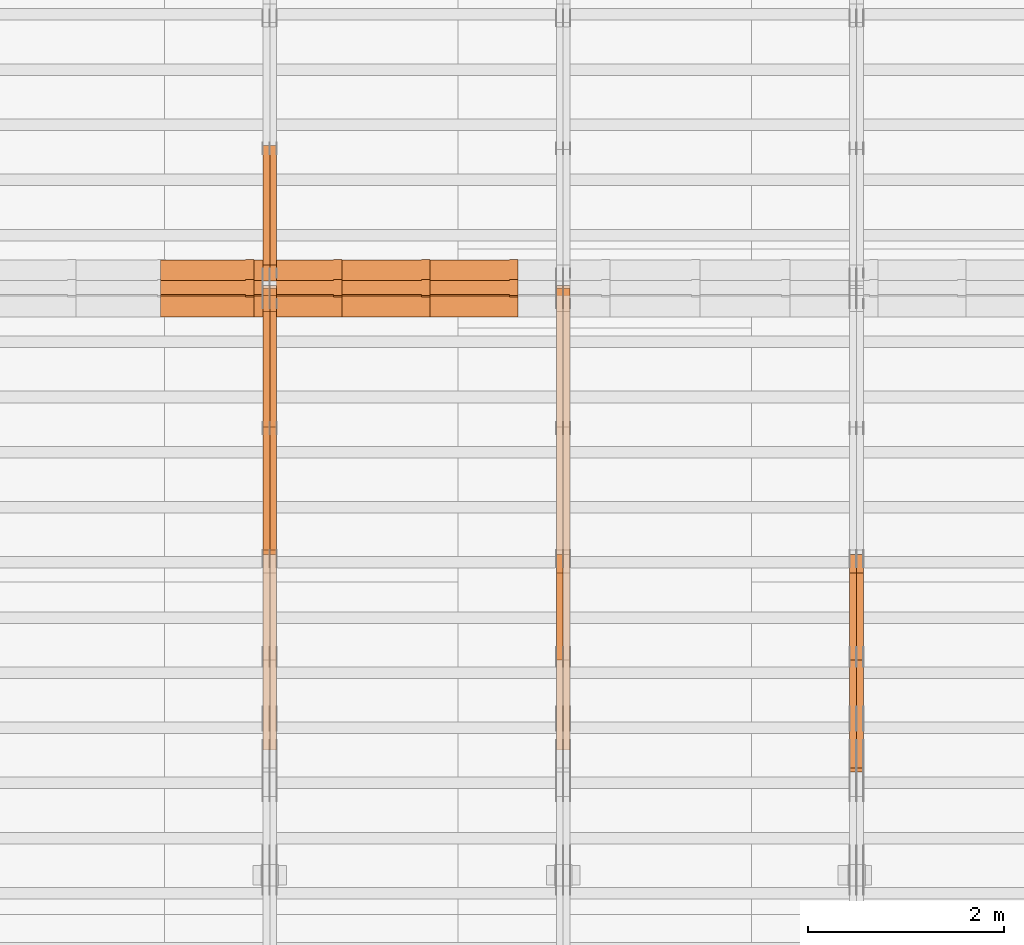
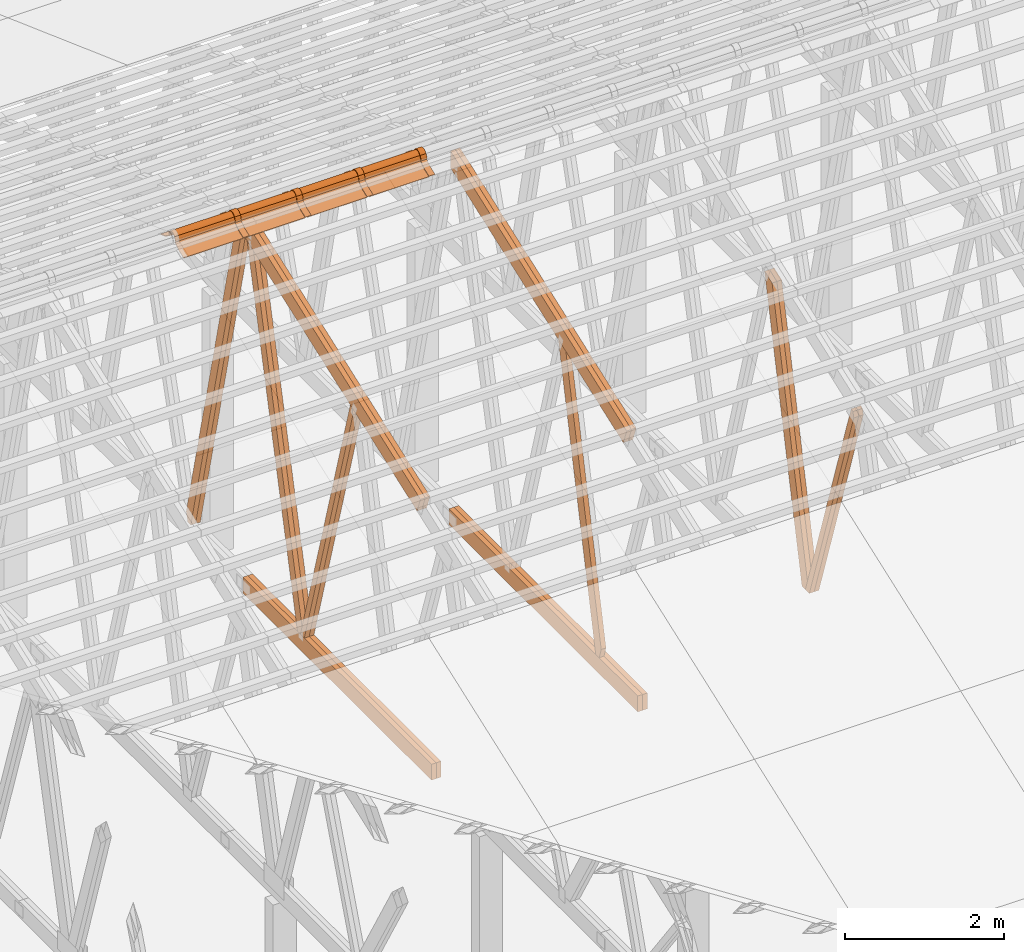
# One storey, part 29 of 189: 27 proxies.
"""IFC2X3 building model written with IfcOpenShell, lengths in millimetres."""

from ifc_helpers import new_model, entity, si_unit, converted_unit, derived_unit, direction, frame, frame_2d, origin, origin_2d_with_axis, place, context, subcontext, project, spatial, polyline, circle_curve, parameter, trimmed, segment, composite_curve, rectangle, outline, extrude, source, transform, mapped, material, type_object, type_shapes, element, save


model = new_model("IFC2X3")

# Units and contexts
model_context = context("Model", 3, precision=0.01, world=origin(), true_north=direction((6.12303176911189e-17, 1.0)))
body_context = subcontext(model_context, "Body", "Model", "MODEL_VIEW")
ifc_project = project(units=[si_unit("LENGTHUNIT", "METRE", prefix="MILLI"), si_unit("AREAUNIT", "SQUARE_METRE"), si_unit("VOLUMEUNIT", "CUBIC_METRE"), converted_unit("PLANEANGLEUNIT", "DEGREE", entity("IfcRatioMeasure", 0.0174532925199433), si_unit("PLANEANGLEUNIT", "RADIAN"), dimensions=[0, 0, 0, 0, 0, 0, 0]), si_unit("MASSUNIT", "GRAM", prefix="KILO"), derived_unit("MASSDENSITYUNIT", [(si_unit("MASSUNIT", "GRAM", prefix="KILO"), 1), (si_unit("LENGTHUNIT", "METRE"), -3)]), si_unit("TIMEUNIT", "SECOND"), si_unit("FREQUENCYUNIT", "HERTZ"), si_unit("THERMODYNAMICTEMPERATUREUNIT", "DEGREE_CELSIUS"), derived_unit("THERMALTRANSMITTANCEUNIT", [(si_unit("MASSUNIT", "GRAM", prefix="KILO"), 1), (si_unit("THERMODYNAMICTEMPERATUREUNIT", "KELVIN"), -1), (si_unit("TIMEUNIT", "SECOND"), -3)]), derived_unit("VOLUMETRICFLOWRATEUNIT", [(si_unit("LENGTHUNIT", "METRE"), 3), (si_unit("TIMEUNIT", "SECOND"), -1)]), si_unit("ELECTRICCURRENTUNIT", "AMPERE"), si_unit("ELECTRICVOLTAGEUNIT", "VOLT"), si_unit("POWERUNIT", "WATT"), si_unit("FORCEUNIT", "NEWTON"), si_unit("ILLUMINANCEUNIT", "LUX"), si_unit("LUMINOUSFLUXUNIT", "LUMEN"), si_unit("LUMINOUSINTENSITYUNIT", "CANDELA"), derived_unit("USERDEFINED", [(si_unit("MASSUNIT", "GRAM", prefix="KILO"), -1), (si_unit("LENGTHUNIT", "METRE"), -2), (si_unit("TIMEUNIT", "SECOND"), 3), (si_unit("LUMINOUSFLUXUNIT", "LUMEN"), 1)]), derived_unit("LINEARVELOCITYUNIT", [(si_unit("LENGTHUNIT", "METRE"), 1), (si_unit("TIMEUNIT", "SECOND"), -1)]), si_unit("PRESSUREUNIT", "PASCAL"), derived_unit("USERDEFINED", [(si_unit("LENGTHUNIT", "METRE"), -2), (si_unit("MASSUNIT", "GRAM", prefix="KILO"), 1), (si_unit("TIMEUNIT", "SECOND"), -2)])], contexts=[model_context])

# Site, building, storey
site_placement = place(None, origin())
site = spatial("IfcSite", under=ifc_project, at=site_placement, CompositionType="ELEMENT")
building_placement = place(site_placement, origin())
building = spatial("IfcBuilding", under=site, at=building_placement, CompositionType="ELEMENT")
storey_placement = place(building_placement, origin())
storey = spatial("IfcBuildingStorey", under=building, at=storey_placement, Name="Default", CompositionType="ELEMENT", Elevation=0.0)

# Proxies
ifc_material_1 = material(Name="IfcSurfaceStyle #162846")
building_element_proxy_type_1 = type_object("IfcBuildingElementProxyType", Name="T1-W3 162844", PredefinedType="NOTDEFINED", material=ifc_material_1)
shared_shape_1 = source(origin(), body_context, "Body", "SweptSolid", [
    extrude(outline(polyline([(-2625.55080717397, -84.9998286237256), (1749.48871563991, -84.9998286237256), (1768.20584427244, 0.000602085469291858), (1625.445846867, 85.0000405971208), (-2517.58959960538, 84.9990145648612), (-2625.55080717397, -84.9998286237256)])), frame((1768.20584427244, 85.0000405971208, 0.0), z_axis=(0.0, 0.0, 1.0), x_axis=(-1.0, 0.0, 0.0)), (0.0, 0.0, 1.0), 69.9999999999997),
])
type_shapes(building_element_proxy_type_1, [shared_shape_1])
proxy_1_placement = place(building_placement, frame((30300.0, 10918.6728403286, 263.278932236374), z_axis=(-1.0, 0.0, 0.0), x_axis=(0.0, 0.215047682154604, 0.976603550269982)))
element("IfcBuildingElementProxy", 1, at=proxy_1_placement, inside=storey, type_object=building_element_proxy_type_1, material=ifc_material_1, Name="T1-W3", context=body_context, shape_type="MappedRepresentation", body=[
    mapped(shared_shape_1, transform((0.0, 0.0, 0.0), scale=1.0)),
])
ifc_material_2 = material(Name="IfcSurfaceStyle #162780")
building_element_proxy_type_2 = type_object("IfcBuildingElementProxyType", Name="T1-W3 162778", PredefinedType="NOTDEFINED", material=ifc_material_2)
shared_shape_2 = source(origin(), body_context, "Body", "SweptSolid", [
    extrude(outline(polyline([(-2625.55080717397, -84.9998286237256), (1749.48871563991, -84.9998286237256), (1768.20584427244, 0.000602085469291858), (1625.445846867, 85.0000405971208), (-2517.58959960538, 84.9990145648612), (-2625.55080717397, -84.9998286237256)])), frame((1768.20584427244, 85.0000405971208, 0.0), z_axis=(0.0, 0.0, 1.0), x_axis=(-1.0, 0.0, 0.0)), (0.0, 0.0, 1.0), 69.9999999999997),
])
type_shapes(building_element_proxy_type_2, [shared_shape_2])
proxy_2_placement = place(building_placement, frame((30230.0, 10918.6728403286, 263.278932236374), z_axis=(-1.0, 0.0, 0.0), x_axis=(0.0, 0.215047682154604, 0.976603550269982)))
element("IfcBuildingElementProxy", 2, at=proxy_2_placement, inside=storey, type_object=building_element_proxy_type_2, material=ifc_material_2, Name="T1-W3", context=body_context, shape_type="MappedRepresentation", body=[
    mapped(shared_shape_2, transform((0.0, 0.0, 0.0), scale=1.0)),
])
ifc_material_3 = material(Name="IfcSurfaceStyle #162582")
building_element_proxy_type_3 = type_object("IfcBuildingElementProxyType", Name="T1-W7 162580", PredefinedType="NOTDEFINED", material=ifc_material_3)
shared_shape_3 = source(origin(), body_context, "Body", "SweptSolid", [
    extrude(outline(polyline([(-2158.15323194511, -47.5001976605119), (1398.58481981178, -47.5001976605119), (1473.93376219819, -0.000131511554346808), (1475.30069254941, 47.5002634162891), (-2189.66604261427, 47.5002634162891), (-2158.15323194511, -47.5001976605119)])), frame((1475.30069254941, 47.5002634162891, 0.0), z_axis=(0.0, 0.0, 1.0), x_axis=(-1.0, 0.0, 0.0)), (0.0, 0.0, 1.0), 69.9999999999998),
])
type_shapes(building_element_proxy_type_3, [shared_shape_3])
proxy_3_placement = place(building_placement, frame((30300.0, 9847.787109375, 3723.57788085937), z_axis=(-1.0, 0.0, 0.0), x_axis=(0.0, 0.314845237923105, -0.949143021971475)))
element("IfcBuildingElementProxy", 3, at=proxy_3_placement, inside=storey, type_object=building_element_proxy_type_3, material=ifc_material_3, Name="T1-W7", context=body_context, shape_type="MappedRepresentation", body=[
    mapped(shared_shape_3, transform((0.0, 0.0, 0.0), scale=1.0)),
])
ifc_material_4 = material(Name="IfcSurfaceStyle #162516")
building_element_proxy_type_4 = type_object("IfcBuildingElementProxyType", Name="T1-W7 162514", PredefinedType="NOTDEFINED", material=ifc_material_4)
shared_shape_4 = source(origin(), body_context, "Body", "SweptSolid", [
    extrude(outline(polyline([(-2158.15323194511, -47.5001976605119), (1398.58481981178, -47.5001976605119), (1473.93376219819, -0.000131511554346808), (1475.30069254941, 47.5002634162891), (-2189.66604261427, 47.5002634162891), (-2158.15323194511, -47.5001976605119)])), frame((1475.30069254941, 47.5002634162891, 0.0), z_axis=(0.0, 0.0, 1.0), x_axis=(-1.0, 0.0, 0.0)), (0.0, 0.0, 1.0), 69.9999999999998),
])
type_shapes(building_element_proxy_type_4, [shared_shape_4])
proxy_4_placement = place(building_placement, frame((30230.0, 9847.787109375, 3723.57788085937), z_axis=(-1.0, 0.0, 0.0), x_axis=(0.0, 0.314845237923105, -0.949143021971475)))
element("IfcBuildingElementProxy", 4, at=proxy_4_placement, inside=storey, type_object=building_element_proxy_type_4, material=ifc_material_4, Name="T1-W7", context=body_context, shape_type="MappedRepresentation", body=[
    mapped(shared_shape_4, transform((0.0, 0.0, 0.0), scale=1.0)),
])
ifc_material_5 = material(Name="IfcSurfaceStyle #146990")
building_element_proxy_type_5 = type_object("IfcBuildingElementProxyType", Name="T1-W3 146988", PredefinedType="NOTDEFINED", material=ifc_material_5)
shared_shape_5 = source(origin(), body_context, "Body", "SweptSolid", [
    extrude(outline(polyline([(-2625.55080717397, -84.9998286237256), (1749.48871563991, -84.9998286237256), (1768.20584427244, 0.000602085469291858), (1625.445846867, 85.0000405971208), (-2517.58959960538, 84.9990145648612), (-2625.55080717397, -84.9998286237256)])), frame((1768.20584427244, 85.0000405971208, 0.0), z_axis=(0.0, 0.0, 1.0), x_axis=(-1.0, 0.0, 0.0)), (0.0, 0.0, 1.0), 69.9999999999997),
])
type_shapes(building_element_proxy_type_5, [shared_shape_5])
proxy_5_placement = place(building_placement, frame((27230.0, 10918.6728403286, 263.278932236374), z_axis=(-1.0, 0.0, 0.0), x_axis=(0.0, 0.215047682154604, 0.976603550269982)))
element("IfcBuildingElementProxy", 5, at=proxy_5_placement, inside=storey, type_object=building_element_proxy_type_5, material=ifc_material_5, Name="T1-W3", context=body_context, shape_type="MappedRepresentation", body=[
    mapped(shared_shape_5, transform((0.0, 0.0, 0.0), scale=1.0)),
])
ifc_material_6 = material(Name="IfcSurfaceStyle #143300")
building_element_proxy_type_6 = type_object("IfcBuildingElementProxyType", Name="T1-B3 143298", PredefinedType="NOTDEFINED", material=ifc_material_6)
shared_shape_6 = source(origin(), body_context, "Body", "SweptSolid", [
    extrude(rectangle(XDim=4751.0283203125, YDim=245.000000000001, at=origin_2d_with_axis()), frame((2375.51416015625, 122.5, 0.0), z_axis=(0.0, 0.0, 1.0), x_axis=(-1.0, 0.0, 0.0)), (0.0, 0.0, 1.0), 69.9999999999997),
])
type_shapes(building_element_proxy_type_6, [shared_shape_6])
proxy_6_placement = place(building_placement, frame((27300.0, 10029.23046875, 245.0), z_axis=(-1.0, 0.0, 0.0), x_axis=(0.0, 1.0, 0.0)))
element("IfcBuildingElementProxy", 6, at=proxy_6_placement, inside=storey, type_object=building_element_proxy_type_6, material=ifc_material_6, Name="T1-B3", context=body_context, shape_type="MappedRepresentation", body=[
    mapped(shared_shape_6, transform((0.0, 0.0, 0.0), scale=1.0)),
])
ifc_material_7 = material(Name="IfcSurfaceStyle #143243")
building_element_proxy_type_7 = type_object("IfcBuildingElementProxyType", Name="T1-B3 143241", PredefinedType="NOTDEFINED", material=ifc_material_7)
shared_shape_7 = source(origin(), body_context, "Body", "SweptSolid", [
    extrude(rectangle(XDim=4751.0283203125, YDim=245.000000000001, at=origin_2d_with_axis()), frame((2375.51416015625, 122.5, 0.0), z_axis=(0.0, 0.0, 1.0), x_axis=(-1.0, 0.0, 0.0)), (0.0, 0.0, 1.0), 69.9999999999997),
])
type_shapes(building_element_proxy_type_7, [shared_shape_7])
proxy_7_placement = place(building_placement, frame((27230.0, 10029.23046875, 245.0), z_axis=(-1.0, 0.0, 0.0), x_axis=(0.0, 1.0, 0.0)))
element("IfcBuildingElementProxy", 7, at=proxy_7_placement, inside=storey, type_object=building_element_proxy_type_7, material=ifc_material_7, Name="T1-B3", context=body_context, shape_type="MappedRepresentation", body=[
    mapped(shared_shape_7, transform((0.0, 0.0, 0.0), scale=1.0)),
])
ifc_material_8 = material(Name="IfcSurfaceStyle #142712")
building_element_proxy_type_8 = type_object("IfcBuildingElementProxyType", Name="T1-T3 142710", PredefinedType="NOTDEFINED", material=ifc_material_8)
shared_shape_8 = source(origin(), body_context, "Body", "SweptSolid", [
    extrude(outline(polyline([(-2341.64890001385, -122.499972785692), (2386.23525922045, -122.499972785692), (2297.06252495753, 122.499972785692), (-2341.64888416412, 122.499972785692), (-2341.64890001385, -122.499972785692)])), frame((2386.23525922045, 122.499973888764, 0.0), z_axis=(0.0, 0.0, 1.0), x_axis=(-1.0, 0.0, 0.0)), (0.0, 0.0, 1.0), 69.9999999999997),
])
type_shapes(building_element_proxy_type_8, [shared_shape_8])
proxy_8_placement = place(building_placement, frame((27300.0, 14833.7949607394, 5538.33627266055), z_axis=(-1.0, 0.0, 0.0), x_axis=(0.0, -0.939692620785908, -0.342020143325669)))
element("IfcBuildingElementProxy", 8, at=proxy_8_placement, inside=storey, type_object=building_element_proxy_type_8, material=ifc_material_8, Name="T1-T3", context=body_context, shape_type="MappedRepresentation", body=[
    mapped(shared_shape_8, transform((0.0, 0.0, 0.0), scale=1.0)),
])
ifc_material_9 = material(Name="IfcSurfaceStyle #142655")
building_element_proxy_type_9 = type_object("IfcBuildingElementProxyType", Name="T1-T3 142653", PredefinedType="NOTDEFINED", material=ifc_material_9)
shared_shape_9 = source(origin(), body_context, "Body", "SweptSolid", [
    extrude(outline(polyline([(-2341.64890001385, -122.499972785692), (2386.23525922045, -122.499972785692), (2297.06252495753, 122.499972785692), (-2341.64888416412, 122.499972785692), (-2341.64890001385, -122.499972785692)])), frame((2386.23525922045, 122.499973888764, 0.0), z_axis=(0.0, 0.0, 1.0), x_axis=(-1.0, 0.0, 0.0)), (0.0, 0.0, 1.0), 69.9999999999997),
])
type_shapes(building_element_proxy_type_9, [shared_shape_9])
proxy_9_placement = place(building_placement, frame((27230.0, 14833.7949607394, 5538.33627266055), z_axis=(-1.0, 0.0, 0.0), x_axis=(0.0, -0.939692620785908, -0.342020143325669)))
element("IfcBuildingElementProxy", 9, at=proxy_9_placement, inside=storey, type_object=building_element_proxy_type_9, material=ifc_material_9, Name="T1-T3", context=body_context, shape_type="MappedRepresentation", body=[
    mapped(shared_shape_9, transform((0.0, 0.0, 0.0), scale=1.0)),
])
ifc_material_10 = material(Name="IfcSurfaceStyle #131794")
building_element_proxy_type_10 = type_object("IfcBuildingElementProxyType", Name="T1-W5 131792", PredefinedType="NOTDEFINED", material=ifc_material_10)
shared_shape_10 = source(origin(), body_context, "Body", "SweptSolid", [
    extrude(outline(polyline([(-3233.61216530572, -72.4999091305202), (2153.79187521892, -72.4999091305202), (2171.36968478227, -7.18521572819375e-05), (2045.62106208646, 72.4999450565989), (-3137.17045678193, 72.4999450565989), (-3233.61216530572, -72.4999091305202)])), frame((2171.36968478227, 72.500192121173, 0.0), z_axis=(0.0, 0.0, 1.0), x_axis=(-1.0, 0.0, 0.0)), (0.0, 0.0, 1.0), 69.9999999999997),
])
type_shapes(building_element_proxy_type_10, [shared_shape_10])
proxy_10_placement = place(building_placement, frame((24300.0, 13261.0146935344, 262.082919891325), z_axis=(-1.0, 0.0, 0.0), x_axis=(0.0, 0.235625623344066, 0.97184389982328)))
element("IfcBuildingElementProxy", 10, at=proxy_10_placement, inside=storey, type_object=building_element_proxy_type_10, material=ifc_material_10, Name="T1-W5", context=body_context, shape_type="MappedRepresentation", body=[
    mapped(shared_shape_10, transform((0.0, 0.0, 0.0), scale=1.0)),
])
ifc_material_11 = material(Name="IfcSurfaceStyle #131728")
building_element_proxy_type_11 = type_object("IfcBuildingElementProxyType", Name="T1-W5 131726", PredefinedType="NOTDEFINED", material=ifc_material_11)
shared_shape_11 = source(origin(), body_context, "Body", "SweptSolid", [
    extrude(outline(polyline([(-3233.61216530572, -72.4999091305202), (2153.79187521892, -72.4999091305202), (2171.36968478227, -7.18521572819375e-05), (2045.62106208646, 72.4999450565989), (-3137.17045678193, 72.4999450565989), (-3233.61216530572, -72.4999091305202)])), frame((2171.36968478227, 72.500192121173, 0.0), z_axis=(0.0, 0.0, 1.0), x_axis=(-1.0, 0.0, 0.0)), (0.0, 0.0, 1.0), 69.9999999999997),
])
type_shapes(building_element_proxy_type_11, [shared_shape_11])
proxy_11_placement = place(building_placement, frame((24230.0, 13261.0146935344, 262.082919891325), z_axis=(-1.0, 0.0, 0.0), x_axis=(0.0, 0.235625623344066, 0.97184389982328)))
element("IfcBuildingElementProxy", 11, at=proxy_11_placement, inside=storey, type_object=building_element_proxy_type_11, material=ifc_material_11, Name="T1-W5", context=body_context, shape_type="MappedRepresentation", body=[
    mapped(shared_shape_11, transform((0.0, 0.0, 0.0), scale=1.0)),
])
ifc_material_12 = material(Name="IfcSurfaceStyle #131662")
building_element_proxy_type_12 = type_object("IfcBuildingElementProxyType", Name="T1-W5 131660", PredefinedType="NOTDEFINED", material=ifc_material_12)
shared_shape_12 = source(origin(), body_context, "Body", "SweptSolid", [
    extrude(outline(polyline([(-3137.17045678193, -72.5002081306407), (2045.62106208646, -72.5002081306408), (2171.36968478227, 5.58426931168476e-05), (2153.79187521892, 72.5001802092942), (-3233.61216530572, 72.5001802092942), (-3137.17045678193, -72.5002081306407)])), frame((2171.36968478227, 72.5001802092942, 0.0), z_axis=(0.0, 0.0, 1.0), x_axis=(-1.0, 0.0, 0.0)), (0.0, 0.0, 1.0), 69.9999999999997),
])
type_shapes(building_element_proxy_type_12, [shared_shape_12])
proxy_12_placement = place(building_placement, frame((24300.0, 16098.0675635854, 227.917113003597), z_axis=(-1.0, 0.0, 0.0), x_axis=(0.0, -0.235625623344066, 0.971843899823279)))
element("IfcBuildingElementProxy", 12, at=proxy_12_placement, inside=storey, type_object=building_element_proxy_type_12, material=ifc_material_12, Name="T1-W5", context=body_context, shape_type="MappedRepresentation", body=[
    mapped(shared_shape_12, transform((0.0, 0.0, 0.0), scale=1.0)),
])
ifc_material_13 = material(Name="IfcSurfaceStyle #131596")
building_element_proxy_type_13 = type_object("IfcBuildingElementProxyType", Name="T1-W5 131594", PredefinedType="NOTDEFINED", material=ifc_material_13)
shared_shape_13 = source(origin(), body_context, "Body", "SweptSolid", [
    extrude(outline(polyline([(-3137.17045678193, -72.5002081306407), (2045.62106208646, -72.5002081306408), (2171.36968478227, 5.58426931168476e-05), (2153.79187521892, 72.5001802092942), (-3233.61216530572, 72.5001802092942), (-3137.17045678193, -72.5002081306407)])), frame((2171.36968478227, 72.5001802092942, 0.0), z_axis=(0.0, 0.0, 1.0), x_axis=(-1.0, 0.0, 0.0)), (0.0, 0.0, 1.0), 69.9999999999997),
])
type_shapes(building_element_proxy_type_13, [shared_shape_13])
proxy_13_placement = place(building_placement, frame((24230.0, 16098.0675635854, 227.917113003597), z_axis=(-1.0, 0.0, 0.0), x_axis=(0.0, -0.235625623344066, 0.971843899823279)))
element("IfcBuildingElementProxy", 13, at=proxy_13_placement, inside=storey, type_object=building_element_proxy_type_13, material=ifc_material_13, Name="T1-W5", context=body_context, shape_type="MappedRepresentation", body=[
    mapped(shared_shape_13, transform((0.0, 0.0, 0.0), scale=1.0)),
])
ifc_material_14 = material(Name="IfcSurfaceStyle #131530")
building_element_proxy_type_14 = type_object("IfcBuildingElementProxyType", Name="T1-W6 131528", PredefinedType="NOTDEFINED", material=ifc_material_14)
shared_shape_14 = source(origin(), body_context, "Body", "SweptSolid", [
    extrude(outline(polyline([(-2640.84340836012, -47.4996765865792), (1711.12245024294, -47.4996765865792), (1797.68490303083, -9.57690019346202e-05), (1800.72595169379, 47.4997244710801), (-2668.68989660745, 47.4997244710801), (-2640.84340836012, -47.4996765865792)])), frame((1800.72595169379, 47.5003009358159, 0.0), z_axis=(0.0, 0.0, 1.0), x_axis=(-1.0, 0.0, 0.0)), (0.0, 0.0, 1.0), 69.9999999999997),
])
type_shapes(building_element_proxy_type_14, [shared_shape_14])
proxy_14_placement = place(building_placement, frame((24300.0, 12074.2896156894, 4533.9586582452), z_axis=(-1.0, 0.0, 0.0), x_axis=(0.0, 0.28128598310461, -0.959623986626467)))
element("IfcBuildingElementProxy", 14, at=proxy_14_placement, inside=storey, type_object=building_element_proxy_type_14, material=ifc_material_14, Name="T1-W6", context=body_context, shape_type="MappedRepresentation", body=[
    mapped(shared_shape_14, transform((0.0, 0.0, 0.0), scale=1.0)),
])
ifc_material_15 = material(Name="IfcSurfaceStyle #131464")
building_element_proxy_type_15 = type_object("IfcBuildingElementProxyType", Name="T1-W6 131462", PredefinedType="NOTDEFINED", material=ifc_material_15)
shared_shape_15 = source(origin(), body_context, "Body", "SweptSolid", [
    extrude(outline(polyline([(-2640.84340836012, -47.4996765865792), (1711.12245024294, -47.4996765865792), (1797.68490303083, -9.57690019346202e-05), (1800.72595169379, 47.4997244710801), (-2668.68989660745, 47.4997244710801), (-2640.84340836012, -47.4996765865792)])), frame((1800.72595169379, 47.5003009358159, 0.0), z_axis=(0.0, 0.0, 1.0), x_axis=(-1.0, 0.0, 0.0)), (0.0, 0.0, 1.0), 69.9999999999997),
])
type_shapes(building_element_proxy_type_15, [shared_shape_15])
proxy_15_placement = place(building_placement, frame((24230.0, 12074.2896156894, 4533.9586582452), z_axis=(-1.0, 0.0, 0.0), x_axis=(0.0, 0.28128598310461, -0.959623986626467)))
element("IfcBuildingElementProxy", 15, at=proxy_15_placement, inside=storey, type_object=building_element_proxy_type_15, material=ifc_material_15, Name="T1-W6", context=body_context, shape_type="MappedRepresentation", body=[
    mapped(shared_shape_15, transform((0.0, 0.0, 0.0), scale=1.0)),
])
ifc_material_16 = material(Name="IfcSurfaceStyle #127510")
building_element_proxy_type_16 = type_object("IfcBuildingElementProxyType", Name="T1-B3 127508", PredefinedType="NOTDEFINED", material=ifc_material_16)
shared_shape_16 = source(origin(), body_context, "Body", "SweptSolid", [
    extrude(rectangle(XDim=4751.0283203125, YDim=245.000000000001, at=origin_2d_with_axis()), frame((2375.51416015625, 122.5, 0.0), z_axis=(0.0, 0.0, 1.0), x_axis=(-1.0, 0.0, 0.0)), (0.0, 0.0, 1.0), 69.9999999999997),
])
type_shapes(building_element_proxy_type_16, [shared_shape_16])
proxy_16_placement = place(building_placement, frame((24300.0, 10029.23046875, 245.0), z_axis=(-1.0, 0.0, 0.0), x_axis=(0.0, 1.0, 0.0)))
element("IfcBuildingElementProxy", 16, at=proxy_16_placement, inside=storey, type_object=building_element_proxy_type_16, material=ifc_material_16, Name="T1-B3", context=body_context, shape_type="MappedRepresentation", body=[
    mapped(shared_shape_16, transform((0.0, 0.0, 0.0), scale=1.0)),
])
ifc_material_17 = material(Name="IfcSurfaceStyle #127453")
building_element_proxy_type_17 = type_object("IfcBuildingElementProxyType", Name="T1-B3 127451", PredefinedType="NOTDEFINED", material=ifc_material_17)
shared_shape_17 = source(origin(), body_context, "Body", "SweptSolid", [
    extrude(rectangle(XDim=4751.0283203125, YDim=245.000000000001, at=origin_2d_with_axis()), frame((2375.51416015625, 122.5, 0.0), z_axis=(0.0, 0.0, 1.0), x_axis=(-1.0, 0.0, 0.0)), (0.0, 0.0, 1.0), 69.9999999999997),
])
type_shapes(building_element_proxy_type_17, [shared_shape_17])
proxy_17_placement = place(building_placement, frame((24230.0, 10029.23046875, 245.0), z_axis=(-1.0, 0.0, 0.0), x_axis=(0.0, 1.0, 0.0)))
element("IfcBuildingElementProxy", 17, at=proxy_17_placement, inside=storey, type_object=building_element_proxy_type_17, material=ifc_material_17, Name="T1-B3", context=body_context, shape_type="MappedRepresentation", body=[
    mapped(shared_shape_17, transform((0.0, 0.0, 0.0), scale=1.0)),
])
ifc_material_18 = material(Name="IfcSurfaceStyle #126922")
building_element_proxy_type_18 = type_object("IfcBuildingElementProxyType", Name="T1-T3 126920", PredefinedType="NOTDEFINED", material=ifc_material_18)
shared_shape_18 = source(origin(), body_context, "Body", "SweptSolid", [
    extrude(outline(polyline([(-2341.64890001385, -122.499972785692), (2386.23525922045, -122.499972785692), (2297.06252495753, 122.499972785692), (-2341.64888416412, 122.499972785692), (-2341.64890001385, -122.499972785692)])), frame((2386.23525922045, 122.499973888764, 0.0), z_axis=(0.0, 0.0, 1.0), x_axis=(-1.0, 0.0, 0.0)), (0.0, 0.0, 1.0), 69.9999999999997),
])
type_shapes(building_element_proxy_type_18, [shared_shape_18])
proxy_18_placement = place(building_placement, frame((24300.0, 14833.7949607394, 5538.33627266055), z_axis=(-1.0, 0.0, 0.0), x_axis=(0.0, -0.939692620785908, -0.342020143325669)))
element("IfcBuildingElementProxy", 18, at=proxy_18_placement, inside=storey, type_object=building_element_proxy_type_18, material=ifc_material_18, Name="T1-T3", context=body_context, shape_type="MappedRepresentation", body=[
    mapped(shared_shape_18, transform((0.0, 0.0, 0.0), scale=1.0)),
])
ifc_material_19 = material(Name="IfcSurfaceStyle #126865")
building_element_proxy_type_19 = type_object("IfcBuildingElementProxyType", Name="T1-T3 126863", PredefinedType="NOTDEFINED", material=ifc_material_19)
shared_shape_19 = source(origin(), body_context, "Body", "SweptSolid", [
    extrude(outline(polyline([(-2341.64890001385, -122.499972785692), (2386.23525922045, -122.499972785692), (2297.06252495753, 122.499972785692), (-2341.64888416412, 122.499972785692), (-2341.64890001385, -122.499972785692)])), frame((2386.23525922045, 122.499973888764, 0.0), z_axis=(0.0, 0.0, 1.0), x_axis=(-1.0, 0.0, 0.0)), (0.0, 0.0, 1.0), 69.9999999999997),
])
type_shapes(building_element_proxy_type_19, [shared_shape_19])
proxy_19_placement = place(building_placement, frame((24230.0, 14833.7949607394, 5538.33627266055), z_axis=(-1.0, 0.0, 0.0), x_axis=(0.0, -0.939692620785908, -0.342020143325669)))
element("IfcBuildingElementProxy", 19, at=proxy_19_placement, inside=storey, type_object=building_element_proxy_type_19, material=ifc_material_19, Name="T1-T3", context=body_context, shape_type="MappedRepresentation", body=[
    mapped(shared_shape_19, transform((0.0, 0.0, 0.0), scale=1.0)),
])
ifc_material_20 = material()
building_element_proxy_type_20 = type_object("IfcBuildingElementProxyType", Name="P75", PredefinedType="NOTDEFINED", material=ifc_material_20)
shared_shape_20 = source(origin(), body_context, "Body", "SweptSolid", [
    extrude(outline(composite_curve([segment(polyline([(-69.4623915065845, -4.60763114971976), (47.4521071665907, -4.60763114971981)]), True, "CONTINUOUS"), segment(trimmed(circle_curve(frame_2d((119.940978060963, 14.6372018310859), x_axis=(-0.966518278591622, -0.256597773077395)), 75.0), [parameter(6.61555373744412e-13)], [parameter(180.0)], True, "PARAMETER"), True, "CONTINUOUS"), segment(polyline([(192.429848955335, 33.882034811891), (182.764666169419, 31.3160570811166)]), True, "CONTINUOUS"), segment(trimmed(circle_curve(frame_2d((119.940978060963, 14.6372018310859), x_axis=(-0.966518278591622, -0.256597773077395)), 65.0), [parameter(1.06866637297174e-12)], [parameter(180.0)], True, "PARAMETER"), False, "CONTINUOUS"), segment(polyline([(57.1172899525073, -2.04165341894578), (47.4521071665911, 5.39236885028051)]), True, "CONTINUOUS"), segment(polyline([(47.4521071665911, 5.39236885028052), (-70.7672243976422, 5.39236885028094)]), True, "CONTINUOUS"), segment(polyline([(-70.7672243976422, 5.39236885028094), (-194.776190618495, -27.5303655446341)]), True, "CONTINUOUS"), segment(polyline([(-194.776190618495, -27.5303655446341), (-192.210212887721, -37.1955483305503)]), True, "CONTINUOUS"), segment(polyline([(-192.210212887721, -37.1955483305503), (-69.4623915065845, -4.60763114971974)]), True, "CONTINUOUS")], self_intersect=False)), frame((0.0, 106.775760402721, -56.5599052870917), z_axis=(1.0, 0.0, 0.0), x_axis=(0.0, -0.820468487122275, 0.571691754041709)), (0.0, 0.0, 1.0), 867.000000000001),
    extrude(outline(composite_curve([segment(polyline([(62.2906866429439, -18.428943356533), (189.290686642944, -18.428943356533)]), True, "CONTINUOUS"), segment(polyline([(189.290686642944, -18.428943356533), (189.290686642944, -8.42894335653292)]), True, "CONTINUOUS"), segment(polyline([(189.290686642944, -8.42894335653292), (62.2906866429439, -8.42894335653294)]), True, "CONTINUOUS"), segment(polyline([(62.2906866429439, -8.42894335653294), (-41.0348065006093, 19.0026034957362)]), True, "CONTINUOUS"), segment(trimmed(circle_curve(frame_2d((-125.709313357056, 11.5710566434651), x_axis=(1.0, 0.0)), 85.0), [parameter(5.01577186738723)], [parameter(180.0)], True, "PARAMETER"), True, "CONTINUOUS"), segment(polyline([(-210.709313357056, 11.5710566434656), (-200.709313357056, 11.5710566434656)]), True, "CONTINUOUS"), segment(trimmed(circle_curve(frame_2d((-125.709313357056, 11.5710566434651), x_axis=(1.0, 0.0)), 75.0), [parameter(3.05333249420498e-13)], [parameter(180.0)], True, "PARAMETER"), False, "CONTINUOUS"), segment(polyline([(-50.7093133570542, 11.5710566434655), (62.290686642944, -18.4289433565322)]), True, "CONTINUOUS")], self_intersect=False)), frame((867.0, 114.170579674061, -53.8683539143053), z_axis=(1.0, 0.0, 0.0), x_axis=(0.0, 0.939692620785914, -0.342020143325653)), (0.0, 0.0, 1.0), 86.9999999999998),
])
type_shapes(building_element_proxy_type_20, [shared_shape_20])
for number, where, name in (
    (20, (25812.9353253273, 14755.0000438631, 5865.69618295448), "P75, generic model20:P75"),
    (21, (24912.9353253273, 14755.0000438631, 5865.69618295448), "P75, generic model20:P75"),
    (22, (24012.9353253273, 14755.0000438631, 5865.69618295448), "P75, generic model20:P75"),
    (23, (23112.9353253273, 14755.0000438631, 5865.69618295448), "P75, generic model20:P75"),
):
    element("IfcBuildingElementProxy", number, at=place(storey_placement, frame(where)), inside=storey, type_object=building_element_proxy_type_20, material=ifc_material_20, Name=name, ObjectType="P75, generic model20:P75", context=body_context, shape_type="MappedRepresentation", body=[
        mapped(shared_shape_20, transform((0.0, 0.0, 0.0), scale=1.0)),
    ])
building_element_proxy_type_21 = type_object("IfcBuildingElementProxyType", Name="P75", PredefinedType="NOTDEFINED", material=ifc_material_20)
shared_shape_21 = source(origin(), body_context, "Body", "SweptSolid", [
    extrude(outline(composite_curve([segment(polyline([(68.3189789579817, 13.3705352460084), (195.318978957982, 13.3705352460084)]), True, "CONTINUOUS"), segment(polyline([(195.318978957982, 13.3705352460084), (195.318978957982, 23.3705352460084)]), True, "CONTINUOUS"), segment(polyline([(195.318978957982, 23.3705352460084), (67.014146066922, 23.3705352460088)]), True, "CONTINUOUS"), segment(polyline([(67.014146066922, 23.3705352460088), (-47.2469987727929, -6.96428196807339)]), True, "CONTINUOUS"), segment(polyline([(-47.2469987727929, -6.96428196807339), (-54.6810210420187, -16.62946475399)]), True, "CONTINUOUS"), segment(trimmed(circle_curve(frame_2d((-119.681021042019, -16.6294647539896), x_axis=(1.0, 0.0)), 65.0), [parameter(180.0)], [parameter(359.999999999999)], True, "PARAMETER"), False, "CONTINUOUS"), segment(polyline([(-184.681021042019, -16.6294647539905), (-194.681021042019, -16.6294647539901)]), True, "CONTINUOUS"), segment(trimmed(circle_curve(frame_2d((-119.681021042019, -16.6294647539896), x_axis=(1.0, 0.0)), 75.0), [parameter(180.0)], [parameter(359.999999999999)], True, "PARAMETER"), True, "CONTINUOUS"), segment(polyline([(-44.6810210420183, -16.6294647539898), (68.3189789579816, 13.3705352460083)]), True, "CONTINUOUS")], self_intersect=False)), frame((0.0, -106.775760402721, -56.5599052870916), z_axis=(1.0, 0.0, 0.0), x_axis=(0.0, -0.939692620785914, -0.342020143325654)), (0.0, 0.0, 1.0), 867.000000000001),
    extrude(outline(composite_curve([segment(polyline([(-64.9339130518847, 1.82825913317695), (-187.681734433021, -30.7596580476538)]), True, "CONTINUOUS"), segment(polyline([(-187.681734433021, -30.7596580476538), (-185.115756702247, -40.4248408335702)]), True, "CONTINUOUS"), segment(polyline([(-185.115756702247, -40.4248408335702), (-62.3679353211107, -7.83692365273935)]), True, "CONTINUOUS"), segment(polyline([(-62.3679353211107, -7.83692365273935), (44.5369162809878, -7.83692365273935)]), True, "CONTINUOUS"), segment(trimmed(circle_curve(frame_2d((124.469456515662, 21.0730921139827), x_axis=(-0.966518278591636, -0.256597773077402)), 85.0), [parameter(5.01577186738723)], [parameter(180.0)], True, "PARAMETER"), True, "CONTINUOUS"), segment(polyline([(206.623510195951, 42.8839028255618), (196.958327410034, 40.3179250947878)]), True, "CONTINUOUS"), segment(trimmed(circle_curve(frame_2d((124.469456515662, 21.0730921139827), x_axis=(-0.966518278591636, -0.256597773077402)), 75.0), [parameter(3.05333249420498e-13)], [parameter(180.0)], True, "PARAMETER"), False, "CONTINUOUS"), segment(polyline([(51.9805856212887, 1.82825913317622), (-64.9339130518846, 1.82825913317621)]), True, "CONTINUOUS")], self_intersect=False)), frame((867.0, -114.170579674061, -53.868353914305), z_axis=(-1.0, 0.0, 0.0), x_axis=(0.0, 0.820468487122275, 0.571691754041709)), (0.0, 0.0, -1.0), 86.9999999999998),
])
type_shapes(building_element_proxy_type_21, [shared_shape_21])
for number, where, name in (
    (24, (25812.9353253273, 14745.0000384614, 5850.69618295448), "P75, generic model20:P75"),
    (25, (24912.9353253273, 14745.0000384614, 5850.69618295448), "P75, generic model20:P75"),
    (26, (24012.9353253273, 14745.0000384614, 5850.69618295448), "P75, generic model20:P75"),
    (27, (23112.9353253273, 14745.0000384614, 5850.69618295448), "P75, generic model20:P75"),
):
    element("IfcBuildingElementProxy", number, at=place(storey_placement, frame(where)), inside=storey, type_object=building_element_proxy_type_21, material=ifc_material_20, Name=name, ObjectType="P75, generic model20:P75", context=body_context, shape_type="MappedRepresentation", body=[
        mapped(shared_shape_21, transform((0.0, 0.0, 0.0), scale=1.0)),
    ])

save(model, "model.ifc")
